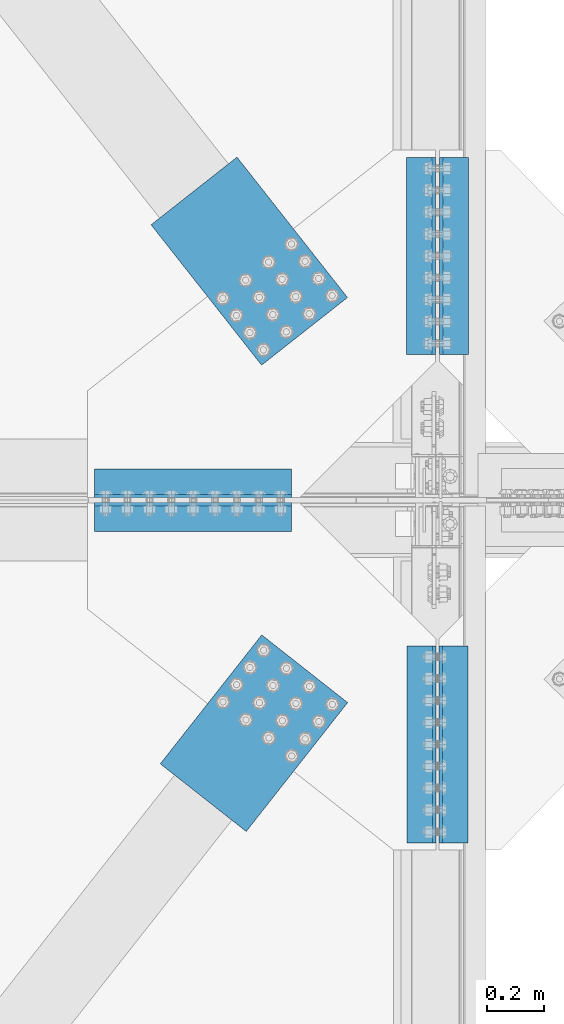
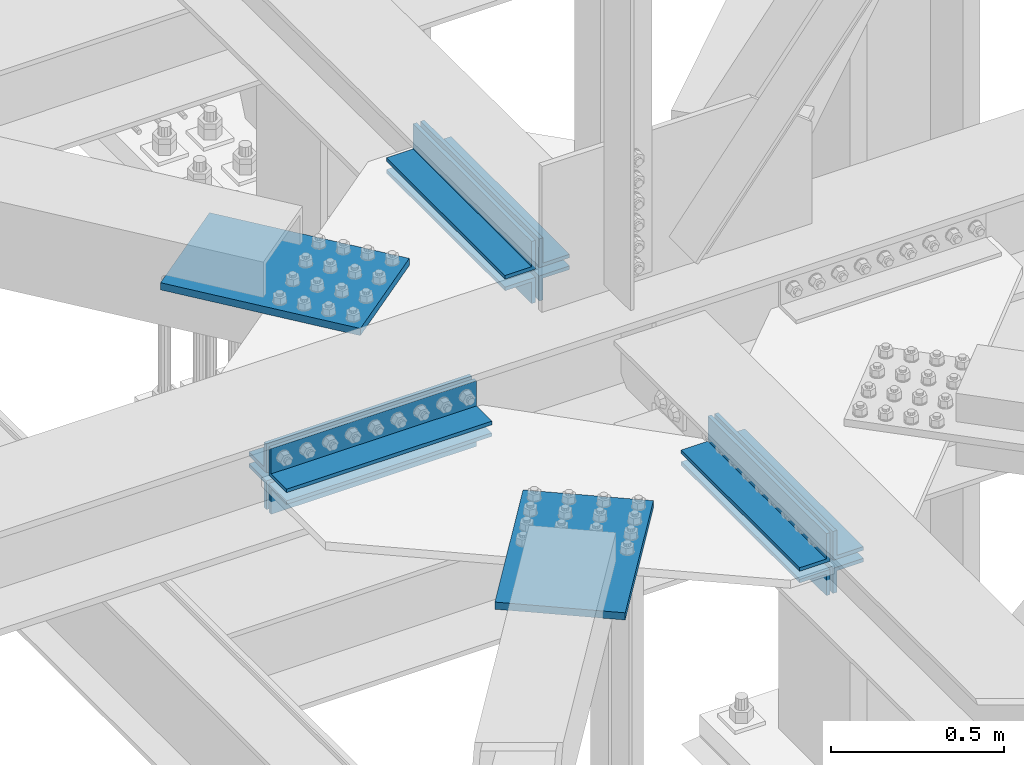
# One storey, part 2474 of 3843: 14 beams, 6 elements without a shape of their own.
"""IFC2X3 building model written with IfcOpenShell, lengths in millimetres."""

from ifc_helpers import new_model, si_unit, frame, origin_with_axes, place, context, subcontext, project, spatial, faceted_brep, material, type_object, element, aggregate, save


model = new_model("IFC2X3")

# Units and contexts
model_context = context("Model", 3, precision=1e-05, world=origin_with_axes())
body_context = subcontext(model_context, "Body", "Model", "MODEL_VIEW")
ifc_project = project(units=[si_unit("LENGTHUNIT", "METRE", prefix="MILLI"), si_unit("AREAUNIT", "SQUARE_METRE"), si_unit("VOLUMEUNIT", "CUBIC_METRE"), si_unit("MASSUNIT", "GRAM", prefix="KILO"), si_unit("TIMEUNIT", "SECOND"), si_unit("PLANEANGLEUNIT", "RADIAN"), si_unit("SOLIDANGLEUNIT", "STERADIAN"), si_unit("THERMODYNAMICTEMPERATUREUNIT", "DEGREE_CELSIUS"), si_unit("LUMINOUSINTENSITYUNIT", "LUMEN")], contexts=[model_context])

# Site, building, storey
site_placement = place(None, origin_with_axes())
site = spatial("IfcSite", under=ifc_project, at=site_placement, CompositionType="ELEMENT")
building_placement = place(site_placement, origin_with_axes())
building = spatial("IfcBuilding", under=site, at=building_placement, Name="Undefined", CompositionType="ELEMENT")
storey_placement = place(building_placement, origin_with_axes())
storey = spatial("IfcBuildingStorey", under=building, at=storey_placement, Name="Undefined", CompositionType="ELEMENT", Elevation=0.0)

# Assembly, beam
assembly_1_placement = place(storey_placement, origin_with_axes())
assembly_1 = element("IfcElementAssembly", 1, at=assembly_1_placement, inside=storey, Name="PLATE", AssemblyPlace="NOTDEFINED", PredefinedType="RIGID_FRAME")
ifc_material = material(Name="STEEL/A572-50")
beam_type_1 = type_object("IfcBeamType", Name="L4X4X1/2", PredefinedType="NOTDEFINED")
beam_1_placement = place(assembly_1_placement, frame((76504.7999999975, 75686.444, 42167.1755004854), z_axis=(0.0, 1.0, 0.0), x_axis=(-1.0, 0.0, 0.0)))
beam_1 = element("IfcBeam", 2, at=beam_1_placement, type_object=beam_type_1, material=ifc_material, Name="ANGLE", ObjectType="L4X4X1/2", context=body_context, shape_type="Brep", body=[
    faceted_brep([(0.0, 50.8000000000029, -50.8000000000029), (0.0, 50.8000000000029, 50.8000000000029), (685.800000000003, 50.8000000000029, 50.8000000000029), (685.800000000003, 50.8000000000029, -50.8000000000029), (0.0, 38.0999999999985, 50.8000000000029), (685.800000000003, 38.0999999999985, 50.8000000000029), (0.0, 38.0999999999985, -38.0999999999985), (685.800000000003, 38.0999999999985, -38.1000000000058), (0.0, -50.8000000000029, -38.1000000000058), (685.800000000003, -50.8000000000029, -38.1000000000058), (0.0, -50.8000000000029, -50.8000000000029), (685.800000000003, -50.8000000000029, -50.8000000000029)], [[[0, 1, 2, 3]], [[1, 4, 5, 2]], [[4, 6, 7, 5]], [[6, 8, 9, 7]], [[8, 10, 11, 9]], [[10, 0, 3, 11]], [[5, 7, 9, 11, 3, 2]], [[10, 8, 6, 4, 1, 0]]]),
])

assembly_2_placement = place(storey_placement, origin_with_axes())
assembly_2 = element("IfcElementAssembly", 3, at=assembly_2_placement, inside=storey, Name="PLATE", AssemblyPlace="NOTDEFINED", PredefinedType="RIGID_FRAME")
beam_2_placement = place(assembly_2_placement, frame((75819.0, 75570.5562499935, 42167.175), z_axis=(0.0, -1.0, 0.0), x_axis=(1.0, 0.0, 0.0)))
beam_2 = element("IfcBeam", 4, at=beam_2_placement, type_object=beam_type_1, material=ifc_material, Name="ANGLE", ObjectType="L4X4X1/2", context=body_context, shape_type="Brep", body=[
    faceted_brep([(0.0, 50.8000000000029, -50.8000000000029), (0.0, 50.8000000000029, 50.8000000000029), (685.800000000003, 50.8000000000029, 50.8000000000029), (685.800000000003, 50.8000000000029, -50.8000000000029), (0.0, 38.0999999999985, 50.8000000000029), (685.800000000003, 38.0999999999985, 50.8000000000029), (0.0, 38.0999999999985, -38.0999999999985), (685.800000000003, 38.0999999999985, -38.1000000000058), (0.0, -50.8000000000029, -38.1000000000058), (685.800000000003, -50.8000000000029, -38.1000000000058), (0.0, -50.8000000000029, -50.8000000000029), (685.800000000003, -50.8000000000029, -50.8000000000029)], [[[0, 1, 2, 3]], [[1, 4, 5, 2]], [[4, 6, 7, 5]], [[6, 8, 9, 7]], [[8, 10, 11, 9]], [[10, 0, 3, 11]], [[5, 7, 9, 11, 3, 2]], [[10, 8, 6, 4, 1, 0]]]),
])

assembly_3_placement = place(storey_placement, origin_with_axes())
assembly_3 = element("IfcElementAssembly", 5, at=assembly_3_placement, inside=storey, Name="PLATE", AssemblyPlace="NOTDEFINED", PredefinedType="RIGID_FRAME")
beam_3_placement = place(assembly_3_placement, frame((77068.362497805, 75120.4999999977, 42297.3511281587), z_axis=(1.0, 0.0, 0.0), x_axis=(0.0, -1.0, 0.0)))
beam_3 = element("IfcBeam", 6, at=beam_3_placement, type_object=beam_type_1, material=ifc_material, Name="ANGLE", ObjectType="L4X4X1/2", context=body_context, shape_type="Brep", body=[
    faceted_brep([(0.0, 50.8000000000029, -50.8000000000029), (0.0, 50.8000000000029, 50.8000000000029), (685.800000000003, 50.8000000000029, 50.8000000000029), (685.800000000003, 50.8000000000029, -50.8000000000029), (0.0, 38.0999999999985, 50.8000000000029), (685.800000000003, 38.0999999999985, 50.8000000000029), (0.0, 38.0999999999985, -38.0999999999985), (685.800000000003, 38.0999999999985, -38.1000000000058), (0.0, -50.8000000000029, -38.1000000000058), (685.800000000003, -50.8000000000029, -38.1000000000058), (0.0, -50.8000000000029, -50.8000000000029), (685.800000000003, -50.8000000000029, -50.8000000000029)], [[[0, 1, 2, 3]], [[1, 4, 5, 2]], [[4, 6, 7, 5]], [[6, 8, 9, 7]], [[8, 10, 11, 9]], [[10, 0, 3, 11]], [[5, 7, 9, 11, 3, 2]], [[10, 8, 6, 4, 1, 0]]]),
])

assembly_4_placement = place(storey_placement, origin_with_axes())
assembly_4 = element("IfcElementAssembly", 7, at=assembly_4_placement, inside=storey, Name="PLATE", AssemblyPlace="NOTDEFINED", PredefinedType="RIGID_FRAME")
beam_4_placement = place(assembly_4_placement, frame((77069.9500000002, 76822.3000000023, 42297.3500007629), z_axis=(1.0, 0.0, 0.0), x_axis=(0.0, -1.0, 0.0)))
beam_4 = element("IfcBeam", 8, at=beam_4_placement, type_object=beam_type_1, material=ifc_material, Name="ANGLE", ObjectType="L4X4X1/2", context=body_context, shape_type="Brep", body=[
    faceted_brep([(0.0, 50.8000000000029, -50.8000000000029), (0.0, 50.8000000000029, 50.8000000000029), (685.800000000003, 50.8000000000029, 50.8000000000029), (685.800000000003, 50.8000000000029, -50.8000000000029), (0.0, 38.0999999999985, 50.8000000000029), (685.800000000003, 38.0999999999985, 50.8000000000029), (0.0, 38.0999999999985, -38.0999999999985), (685.800000000003, 38.0999999999985, -38.1000000000058), (0.0, -50.8000000000029, -38.1000000000058), (685.800000000003, -50.8000000000029, -38.1000000000058), (0.0, -50.8000000000029, -50.8000000000029), (685.800000000003, -50.8000000000029, -50.8000000000029)], [[[0, 1, 2, 3]], [[1, 4, 5, 2]], [[4, 6, 7, 5]], [[6, 8, 9, 7]], [[8, 10, 11, 9]], [[10, 0, 3, 11]], [[5, 7, 9, 11, 3, 2]], [[10, 8, 6, 4, 1, 0]]]),
])

# Beam
beam_5_placement = place(assembly_2_placement, frame((76504.800000001, 75570.55625, 42297.350000761), z_axis=(0.0, -1.0, 0.0), x_axis=(-1.0, 0.0, 0.0)))
beam_5 = element("IfcBeam", 9, at=beam_5_placement, type_object=beam_type_1, material=ifc_material, Name="ANGLE", ObjectType="L4X4X1/2", context=body_context, shape_type="Brep", body=[
    faceted_brep([(0.0, 50.8000000000029, -50.8000000000029), (0.0, 50.8000000000029, 50.8000000000029), (685.800000000003, 50.8000000000029, 50.8000000000029), (685.800000000003, 50.8000000000029, -50.8000000000029), (0.0, 38.0999999999985, 50.8000000000029), (685.800000000003, 38.0999999999985, 50.8000000000029), (0.0, 38.0999999999985, -38.0999999999985), (685.800000000003, 38.0999999999985, -38.1000000000058), (0.0, -50.8000000000029, -38.1000000000058), (685.800000000003, -50.8000000000029, -38.1000000000058), (0.0, -50.8000000000029, -50.8000000000029), (685.800000000003, -50.8000000000029, -50.8000000000029)], [[[0, 1, 2, 3]], [[1, 4, 5, 2]], [[4, 6, 7, 5]], [[6, 8, 9, 7]], [[8, 10, 11, 9]], [[10, 0, 3, 11]], [[5, 7, 9, 11, 3, 2]], [[10, 8, 6, 4, 1, 0]]]),
])

beam_6_placement = place(assembly_2_placement, frame((76957.237497805, 74434.6999999978, 42297.3511281587), z_axis=(-1.0, 0.0, 0.0), x_axis=(0.0, 1.0, 0.0)))
beam_6 = element("IfcBeam", 10, at=beam_6_placement, type_object=beam_type_1, material=ifc_material, Name="ANGLE", ObjectType="L4X4X1/2", context=body_context, shape_type="Brep", body=[
    faceted_brep([(0.0, 50.8000000000029, -50.8000000000029), (0.0, 50.8000000000029, 50.8000000000029), (685.800000000003, 50.8000000000029, 50.8000000000029), (685.800000000003, 50.8000000000029, -50.8000000000029), (0.0, 38.0999999999985, 50.8000000000029), (685.800000000003, 38.0999999999985, 50.8000000000029), (0.0, 38.0999999999985, -38.0999999999985), (685.800000000003, 38.0999999999985, -38.1000000000058), (0.0, -50.8000000000029, -38.1000000000058), (685.800000000003, -50.8000000000029, -38.1000000000058), (0.0, -50.8000000000029, -50.8000000000029), (685.800000000003, -50.8000000000029, -50.8000000000029)], [[[0, 1, 2, 3]], [[1, 4, 5, 2]], [[4, 6, 7, 5]], [[6, 8, 9, 7]], [[8, 10, 11, 9]], [[10, 0, 3, 11]], [[5, 7, 9, 11, 3, 2]], [[10, 8, 6, 4, 1, 0]]]),
])

beam_7_placement = place(assembly_1_placement, frame((75819.000000001, 75686.44375, 42297.350000761), z_axis=(0.0, 1.0, 0.0), x_axis=(1.0, 0.0, 0.0)))
beam_7 = element("IfcBeam", 11, at=beam_7_placement, type_object=beam_type_1, material=ifc_material, Name="ANGLE", ObjectType="L4X4X1/2", context=body_context, shape_type="Brep", body=[
    faceted_brep([(0.0, 50.8000000000029, -50.8000000000029), (0.0, 50.8000000000029, 50.8000000000029), (685.800000000003, 50.8000000000029, 50.8000000000029), (685.800000000003, 50.8000000000029, -50.8000000000029), (0.0, 38.0999999999985, 50.8000000000029), (685.800000000003, 38.0999999999985, 50.8000000000029), (0.0, 38.0999999999985, -38.0999999999985), (685.800000000003, 38.0999999999985, -38.1000000000058), (0.0, -50.8000000000029, -38.1000000000058), (685.800000000003, -50.8000000000029, -38.1000000000058), (0.0, -50.8000000000029, -50.8000000000029), (685.800000000003, -50.8000000000029, -50.8000000000029)], [[[0, 1, 2, 3]], [[1, 4, 5, 2]], [[4, 6, 7, 5]], [[6, 8, 9, 7]], [[8, 10, 11, 9]], [[10, 0, 3, 11]], [[5, 7, 9, 11, 3, 2]], [[10, 8, 6, 4, 1, 0]]]),
])

beam_8_placement = place(assembly_1_placement, frame((76955.6499999998, 76136.5000000023, 42297.3500007629), z_axis=(-1.0, 0.0, 0.0), x_axis=(0.0, 1.0, 0.0)))
beam_8 = element("IfcBeam", 12, at=beam_8_placement, type_object=beam_type_1, material=ifc_material, Name="ANGLE", ObjectType="L4X4X1/2", context=body_context, shape_type="Brep", body=[
    faceted_brep([(0.0, 50.8000000000029, -50.8000000000029), (0.0, 50.8000000000029, 50.8000000000029), (685.800000000003, 50.8000000000029, 50.8000000000029), (685.800000000003, 50.8000000000029, -50.8000000000029), (0.0, 38.0999999999985, 50.8000000000029), (685.800000000003, 38.0999999999985, 50.8000000000029), (0.0, 38.0999999999985, -38.0999999999985), (685.800000000003, 38.0999999999985, -38.1000000000058), (0.0, -50.8000000000029, -38.1000000000058), (685.800000000003, -50.8000000000029, -38.1000000000058), (0.0, -50.8000000000029, -50.8000000000029), (685.800000000003, -50.8000000000029, -50.8000000000029)], [[[0, 1, 2, 3]], [[1, 4, 5, 2]], [[4, 6, 7, 5]], [[6, 8, 9, 7]], [[8, 10, 11, 9]], [[10, 0, 3, 11]], [[5, 7, 9, 11, 3, 2]], [[10, 8, 6, 4, 1, 0]]]),
])

beam_type_2 = type_object("IfcBeamType", Name="L4X3-1/2X1/2", PredefinedType="NOTDEFINED")
beam_9_placement = place(assembly_1_placement, frame((76955.6499999998, 76822.3000000023, 42173.5249984741), z_axis=(-1.0, 0.0, 0.0), x_axis=(0.0, -1.0, 0.0)))
beam_9 = element("IfcBeam", 13, at=beam_9_placement, type_object=beam_type_2, material=ifc_material, Name="ANGLE", ObjectType="L4X3-1/2X1/2", context=body_context, shape_type="Brep", body=[
    faceted_brep([(0.0, 44.4499999999971, -50.8000000000029), (0.0, 44.4499999999971, 50.8000000000029), (685.800000000003, 44.4499999999971, 50.8000000000029), (685.800000000003, 44.4499999999971, -50.8000000000029), (0.0, 31.75, 50.8000000000029), (685.800000000003, 31.75, 50.8000000000029), (0.0, 31.7500000838336, -38.0999999999985), (685.800000000003, 31.75, -38.0999999999985), (4.36557456851006e-11, -44.4500000000226, -38.0999999999985), (685.800000000003, -44.4499999999971, -38.0999999999985), (0.0, -44.4499999999971, -50.8000000000029), (685.800000000003, -44.4499999999971, -50.8000000000029)], [[[0, 1, 2, 3]], [[1, 4, 5, 2]], [[4, 6, 7, 5]], [[6, 8, 9, 7]], [[8, 10, 11, 9]], [[10, 0, 3, 11]], [[5, 7, 9, 11, 3, 2]], [[10, 8, 6, 4, 1, 0]]]),
])

aggregate(assembly_1, [beam_9, beam_1, beam_7, beam_8])

beam_10_placement = place(assembly_2_placement, frame((76957.237497805, 75120.4999999977, 42173.5261258699), z_axis=(-1.0, 0.0, 0.0), x_axis=(0.0, -1.0, 0.0)))
beam_10 = element("IfcBeam", 14, at=beam_10_placement, type_object=beam_type_2, material=ifc_material, Name="ANGLE", ObjectType="L4X3-1/2X1/2", context=body_context, shape_type="Brep", body=[
    faceted_brep([(0.0, 44.4499999999971, -50.8000000000029), (0.0, 44.4499999999971, 50.8000000000029), (685.800000000003, 44.4499999999971, 50.8000000000029), (685.800000000003, 44.4499999999971, -50.8000000000029), (0.0, 31.75, 50.8000000000029), (685.800000000003, 31.75, 50.8000000000029), (0.0, 31.7500000838336, -38.0999999999985), (685.800000000003, 31.75, -38.0999999999985), (4.36557456851006e-11, -44.4500000000226, -38.0999999999985), (685.800000000003, -44.4499999999971, -38.0999999999985), (0.0, -44.4499999999971, -50.8000000000029), (685.800000000003, -44.4499999999971, -50.8000000000029)], [[[0, 1, 2, 3]], [[1, 4, 5, 2]], [[4, 6, 7, 5]], [[6, 8, 9, 7]], [[8, 10, 11, 9]], [[10, 0, 3, 11]], [[5, 7, 9, 11, 3, 2]], [[10, 8, 6, 4, 1, 0]]]),
])

aggregate(assembly_2, [beam_10, beam_2, beam_5, beam_6])

beam_11_placement = place(assembly_4_placement, frame((77069.9500000002, 76136.5000000023, 42173.525), z_axis=(1.0, 0.0, 0.0), x_axis=(0.0, 1.0, 0.0)))
beam_11 = element("IfcBeam", 15, at=beam_11_placement, type_object=beam_type_2, material=ifc_material, Name="ANGLE", ObjectType="L4X3-1/2X1/2", context=body_context, shape_type="Brep", body=[
    faceted_brep([(0.0, 44.4499999999971, -50.8000000000029), (0.0, 44.4499999999971, 50.8000000000029), (685.800000000003, 44.4499999999971, 50.8000000000029), (685.800000000003, 44.4499999999971, -50.8000000000029), (0.0, 31.75, 50.8000000000029), (685.800000000003, 31.75, 50.8000000000029), (0.0, 31.7500000838336, -38.0999999999985), (685.800000000003, 31.75, -38.0999999999985), (4.36557456851006e-11, -44.4500000000226, -38.0999999999985), (685.800000000003, -44.4499999999971, -38.0999999999985), (0.0, -44.4499999999971, -50.8000000000029), (685.800000000003, -44.4499999999971, -50.8000000000029)], [[[0, 1, 2, 3]], [[1, 4, 5, 2]], [[4, 6, 7, 5]], [[6, 8, 9, 7]], [[8, 10, 11, 9]], [[10, 0, 3, 11]], [[5, 7, 9, 11, 3, 2]], [[10, 8, 6, 4, 1, 0]]]),
])

aggregate(assembly_4, [beam_11, beam_4])

beam_12_placement = place(assembly_3_placement, frame((77068.362497805, 74434.6999999977, 42173.5261273958), z_axis=(1.0, 0.0, 0.0), x_axis=(0.0, 1.0, 0.0)))
beam_12 = element("IfcBeam", 16, at=beam_12_placement, type_object=beam_type_2, material=ifc_material, Name="ANGLE", ObjectType="L4X3-1/2X1/2", context=body_context, shape_type="Brep", body=[
    faceted_brep([(0.0, 44.4499999999971, -50.8000000000029), (0.0, 44.4499999999971, 50.8000000000029), (685.800000000003, 44.4499999999971, 50.8000000000029), (685.800000000003, 44.4499999999971, -50.8000000000029), (0.0, 31.75, 50.8000000000029), (685.800000000003, 31.75, 50.8000000000029), (0.0, 31.7500000838336, -38.0999999999985), (685.800000000003, 31.75, -38.0999999999985), (4.36557456851006e-11, -44.4500000000226, -38.0999999999985), (685.800000000003, -44.4499999999971, -38.0999999999985), (0.0, -44.4499999999971, -50.8000000000029), (685.800000000003, -44.4499999999971, -50.8000000000029)], [[[0, 1, 2, 3]], [[1, 4, 5, 2]], [[4, 6, 7, 5]], [[6, 8, 9, 7]], [[8, 10, 11, 9]], [[10, 0, 3, 11]], [[5, 7, 9, 11, 3, 2]], [[10, 8, 6, 4, 1, 0]]]),
])

aggregate(assembly_3, [beam_12, beam_3])

# Assembly, beam
assembly_5_placement = place(storey_placement, origin_with_axes())
assembly_5 = element("IfcElementAssembly", 17, at=assembly_5_placement, inside=storey, AssemblyPlace="NOTDEFINED", PredefinedType="RIGID_FRAME")
beam_type_3 = type_object("IfcBeamType", PredefinedType="NOTDEFINED")
beam_13_placement = place(assembly_5_placement, frame((76550.4637338072, 75041.2079872565, 42259.2506270982), z_axis=(0.785737878354044, -0.61855960627872, 0.0), x_axis=(-0.618559605175322, -0.785737879222676, 0.0)))
beam_13 = element("IfcBeam", 18, at=beam_13_placement, type_object=beam_type_3, material=ifc_material, Name="PLATE", context=body_context, shape_type="Brep", body=[
    faceted_brep([(5.85714587941766e-10, 12.6999999999971, -190.500000000349), (-6.14818418398499e-10, 12.6999999999971, 190.500000000364), (571.499999996191, 12.6999999999971, 190.49999999936), (571.499999997392, 12.6999999999971, -190.500000001353), (-6.14818418398499e-10, -12.6999999999971, 190.500000000364), (571.499999996191, -12.6999999999971, 190.49999999936), (5.85714587941766e-10, -12.6999999999971, -190.500000000349), (571.499999997392, -12.6999999999971, -190.500000001353)], [[[0, 1, 2, 3]], [[1, 4, 5, 2]], [[4, 6, 7, 5]], [[6, 0, 3, 7]], [[5, 7, 3, 2]], [[6, 4, 1, 0]]]),
])
aggregate(assembly_5, [beam_13])

assembly_6_placement = place(storey_placement, origin_with_axes())
assembly_6 = element("IfcElementAssembly", 19, at=assembly_6_placement, inside=storey, AssemblyPlace="NOTDEFINED", PredefinedType="RIGID_FRAME")
beam_14_placement = place(assembly_6_placement, frame((76549.8563323918, 76216.5635779904, 42259.2489992142), z_axis=(0.785737876999385, 0.618559607999504, 0.0), x_axis=(-0.618559606896105, 0.785737877868018, 0.0)))
beam_14 = element("IfcBeam", 20, at=beam_14_placement, type_object=beam_type_3, material=ifc_material, Name="PLATE", context=body_context, shape_type="Brep", body=[
    faceted_brep([(5.85714587941766e-10, 12.6999999999971, -190.500000000349), (-6.14818418398499e-10, 12.6999999999971, 190.500000000364), (622.299987794569, 12.6999999999971, 190.499999998057), (622.299987793129, 12.6999999999971, -190.500000002765), (-6.14818418398499e-10, -12.6999999999971, 190.500000000364), (622.299987794569, -12.6999999999971, 190.499999998057), (5.85714587941766e-10, -12.6999999999971, -190.500000000349), (622.299987793129, -12.6999999999971, -190.500000002765)], [[[0, 1, 2, 3]], [[1, 4, 5, 2]], [[4, 6, 7, 5]], [[6, 0, 3, 7]], [[5, 7, 3, 2]], [[6, 4, 1, 0]]]),
])
aggregate(assembly_6, [beam_14])

save(model, "model.ifc")
